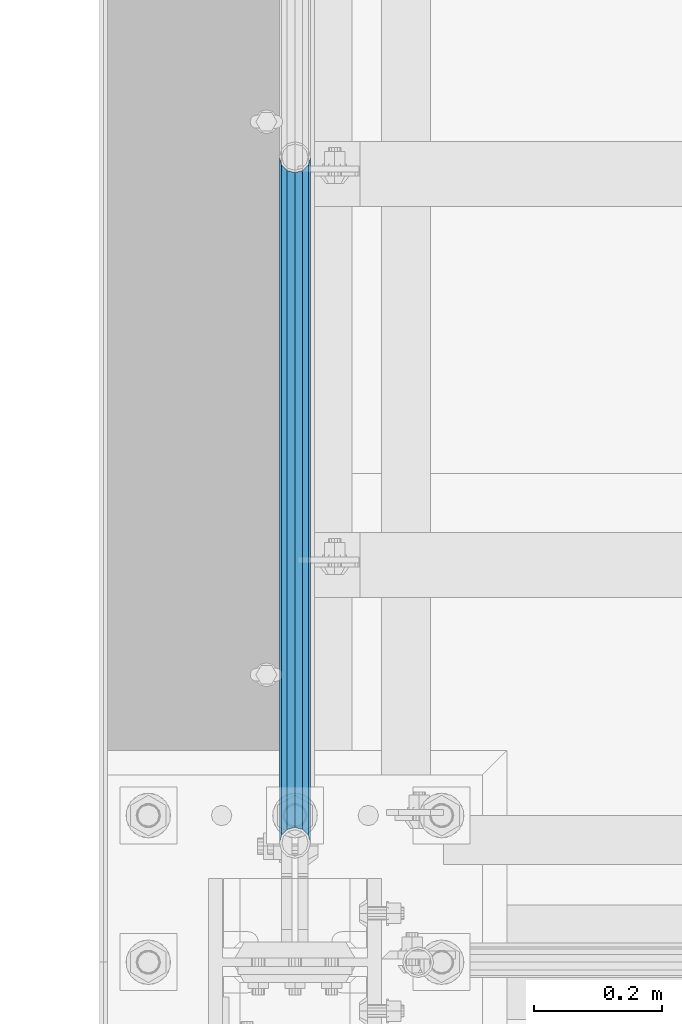
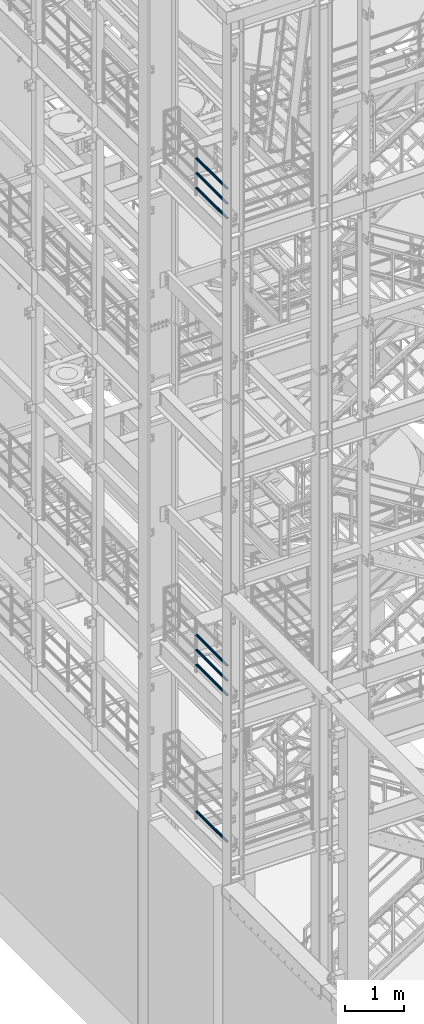
# One storey, part 933 of 1876: 7 beams, 3 elements without a shape of their own.
"""IFC2X3 building model written with IfcOpenShell, lengths in millimetres."""

import ifcopenshell
import ifcopenshell.guid

model = None  # the IFC model being written
_history = None  # IfcOwnerHistory: only IFC2X3 demands one
_inside = {}  # id of a spatial element -> (the spatial element, [elements in it])
_under = {}  # id of a project, library or spatial element -> (it, [spatial elements below it])
_declared = {}  # id of a project -> (the project, [libraries it declares])
_typed = {}  # id of a type object -> (the type object, [elements of that type])
_made_of = {}  # id of a material, layer set ... -> (it, [elements and type objects made of it])


def new_model(schema):
    """Start an empty IFC model of exactly this schema.

    Asked for "IFC4X3", IfcOpenShell would pick the latest addendum, in which some entities
    have other attributes; the version numbers below select the first issue.
    IFC2X3 requires an IfcOwnerHistory on every rooted entity: one is made here for all.
    """
    global model, _history
    if schema == "IFC4X3":
        model = ifcopenshell.file(schema_version=(4, 3, 0, 0))
    else:
        model = ifcopenshell.file(schema=schema)
    _inside.clear()
    _under.clear()
    _declared.clear()
    _typed.clear()
    _made_of.clear()
    _history = None
    if model.schema == "IFC2X3":
        org = make("IfcOrganization", Name="unknown")
        user = make(
            "IfcPersonAndOrganization",
            ThePerson=make("IfcPerson", FamilyName="unknown"),
            TheOrganization=org,
        )
        app = make(
            "IfcApplication",
            ApplicationDeveloper=org,
            Version="unknown",
            ApplicationFullName="unknown",
            ApplicationIdentifier="unknown",
        )
        _history = make(
            "IfcOwnerHistory",
            OwningUser=user,
            OwningApplication=app,
            ChangeAction="ADDED",
            CreationDate=0,
        )
    return model


def make(cls, **values):
    """One entity of the class cls with the attributes given. An attribute that is None is left unset."""
    return model.create_entity(
        cls, **{name: value for name, value in values.items() if value is not None}
    )


def rooted(cls, **values):
    """An entity with a GlobalId (a new one), such as an element, a storey or a relation."""
    return make(cls, GlobalId=ifcopenshell.guid.new(), OwnerHistory=_history, **values)


def si_unit(unit_type, name, prefix=None):
    """IfcSIUnit, for example si_unit("LENGTHUNIT", "METRE", prefix="MILLI")."""
    return make("IfcSIUnit", UnitType=unit_type, Prefix=prefix, Name=name)


def assignment(units):
    """IfcUnitAssignment: the units of a project."""
    return None if units is None else make("IfcUnitAssignment", Units=units)


def point(xyz):
    """IfcCartesianPoint."""
    return None if xyz is None else make("IfcCartesianPoint", Coordinates=xyz)


def direction(xyz):
    """IfcDirection."""
    return None if xyz is None else make("IfcDirection", DirectionRatios=xyz)


def frame(location, z_axis=None, x_axis=None):
    """IfcAxis2Placement3D, a coordinate frame: its origin and axes. An axis left out is left unset."""
    return make(
        "IfcAxis2Placement3D",
        Location=point(location),
        Axis=direction(z_axis),
        RefDirection=direction(x_axis),
    )


def origin_with_axes():
    """The frame at (0, 0, 0) with the z axis (0, 0, 1) and the x axis (1, 0, 0) written out."""
    return frame((0.0, 0.0, 0.0), z_axis=(0.0, 0.0, 1.0), x_axis=(1.0, 0.0, 0.0))


def place(relative_to, where):
    """IfcLocalPlacement: puts the frame where relative to a parent placement (None: the world)."""
    return make(
        "IfcLocalPlacement", PlacementRelTo=relative_to, RelativePlacement=where
    )


def context(
    kind, dimensions, precision=None, world=None, true_north=None, identifier=None
):
    """IfcGeometricRepresentationContext, for example the 3D "Model" context."""
    return make(
        "IfcGeometricRepresentationContext",
        ContextIdentifier=identifier,
        ContextType=kind,
        CoordinateSpaceDimension=dimensions,
        Precision=precision,
        WorldCoordinateSystem=world,
        TrueNorth=true_north,
    )


def subcontext(parent, identifier, kind, view, scale=None):
    """IfcGeometricRepresentationSubContext, for example "Body" below "Model"."""
    return make(
        "IfcGeometricRepresentationSubContext",
        ContextIdentifier=identifier,
        ContextType=kind,
        ParentContext=parent,
        TargetScale=scale,
        TargetView=view,
    )


def project(units=None, contexts=None):
    """IfcProject with its units and contexts."""
    return rooted(
        "IfcProject",
        Name="project",
        RepresentationContexts=contexts,
        UnitsInContext=assignment(units),
    )


def spatial(cls, under=None, at=None, **own):
    """A site, building, storey or space (cls), placed at a placement, below another one or the project."""
    s = rooted(cls, ObjectPlacement=at, **own)
    if under is not None:
        _under.setdefault(under.id(), (under, []))[1].append(s)
    return s


def faces_of(points, faces, orient=None, outer=None):
    """IfcFace entities. A face is a list of loops; a loop is a list of indices into points, from 0.

    orient and outer hold one flag for each loop. By default every Orientation is true, the
    first loop of a face is its IfcFaceOuterBound and the others are IfcFaceBound.
    """
    made = []
    for i, loops in enumerate(faces):
        bounds = []
        for j, loop in enumerate(loops):
            is_outer = j == 0 if outer is None else outer[i][j]
            bounds.append(
                make(
                    "IfcFaceOuterBound" if is_outer else "IfcFaceBound",
                    Bound=make("IfcPolyLoop", Polygon=[points[k] for k in loop]),
                    Orientation=True if orient is None else orient[i][j],
                )
            )
        made.append(make("IfcFace", Bounds=bounds))
    return made


def faceted_brep(points, faces, orient=None, outer=None, voids=None):
    """IfcFacetedBrep: a solid bounded by flat faces; with voids (closed shells), ...WithVoids."""
    shared = [point(p) for p in points]
    hull = make("IfcClosedShell", CfsFaces=faces_of(shared, faces, orient, outer))
    if voids is None:
        return make("IfcFacetedBrep", Outer=hull)
    return make(
        "IfcFacetedBrepWithVoids",
        Outer=hull,
        Voids=[
            make(cls, CfsFaces=faces_of(shared, fs, o, b)) for cls, fs, o, b in voids
        ],
    )


def shape(context_of_items, identifier, shape_type, items):
    """IfcShapeRepresentation: the items that make up one representation, for example the "Body"."""
    return make(
        "IfcShapeRepresentation",
        ContextOfItems=context_of_items,
        RepresentationIdentifier=identifier,
        RepresentationType=shape_type,
        Items=items,
    )


def material(Name=None, Category=None):
    """IfcMaterial."""
    return make("IfcMaterial", Name=Name, Category=Category)


def made_of(thing, what):
    """Note that an element or type object is made of a material, layer set ...; save() writes the relation."""
    if what is not None:
        _made_of.setdefault(what.id(), (what, []))[1].append(thing)
    return thing


def type_object(cls, material=None, **own):
    """A type object (cls), such as IfcWallType, which elements share."""
    return made_of(rooted(cls, **own), material)


def element(
    cls,
    number,
    at=None,
    inside=None,
    cuts=None,
    type_object=None,
    material=None,
    context=None,
    identifier="Body",
    shape_type=None,
    held_by="IfcProductDefinitionShape",
    body=None,
    shapes=None,
    **own,
):
    """One element of the class cls, such as IfcWall. Its Tag is "e" and its number.

    at: its placement. inside: the storey or other place that contains it. cuts: it is an
    opening in that element (IfcRelVoidsElement). A single representation is given by context,
    identifier, shape_type and body (its items); several are given by shapes. held_by: the class
    of the entity that holds the representations. save() writes the other relations.
    """
    e = rooted(cls, Tag="e%d" % number, ObjectPlacement=at, **own)
    if body is not None:
        shapes = [shape(context, identifier, shape_type, body)]
    if shapes is not None:
        e.Representation = make(held_by, Representations=shapes)
    if inside is not None:
        _inside.setdefault(inside.id(), (inside, []))[1].append(e)
    if cuts is not None:
        rooted(
            "IfcRelVoidsElement", RelatingBuildingElement=cuts, RelatedOpeningElement=e
        )
    if type_object is not None:
        _typed.setdefault(type_object.id(), (type_object, []))[1].append(e)
    return made_of(e, material)


def aggregate(whole, parts):
    """IfcRelAggregates: a whole, such as a stair, and the parts it consists of."""
    return rooted("IfcRelAggregates", RelatingObject=whole, RelatedObjects=parts)


def save(model, path):
    """Write the relations noted so far, then the file.

    IfcRelAggregates (storeys below a building ...), IfcRelContainedInSpatialStructure (elements
    in a storey), IfcRelDefinesByType, IfcRelAssociatesMaterial and IfcRelDeclares: one each for
    every whole, place, type object, material and project.
    """
    for whole, parts in _under.values():
        aggregate(whole, parts)
    for where, things in _inside.values():
        rooted(
            "IfcRelContainedInSpatialStructure",
            RelatedElements=things,
            RelatingStructure=where,
        )
    for kind, things in _typed.values():
        rooted("IfcRelDefinesByType", RelatedObjects=things, RelatingType=kind)
    for what, things in _made_of.values():
        rooted("IfcRelAssociatesMaterial", RelatedObjects=things, RelatingMaterial=what)
    for by, libraries in _declared.values():
        rooted("IfcRelDeclares", RelatingContext=by, RelatedDefinitions=libraries)
    model.write(path)


model = new_model("IFC2X3")

# Units and contexts
model_context = context("Model", 3, precision=1e-05, world=origin_with_axes())
body_context = subcontext(model_context, "Body", "Model", "MODEL_VIEW")
ifc_project = project(units=[si_unit("LENGTHUNIT", "METRE", prefix="MILLI"), si_unit("AREAUNIT", "SQUARE_METRE"), si_unit("VOLUMEUNIT", "CUBIC_METRE"), si_unit("MASSUNIT", "GRAM", prefix="KILO"), si_unit("TIMEUNIT", "SECOND"), si_unit("PLANEANGLEUNIT", "RADIAN"), si_unit("SOLIDANGLEUNIT", "STERADIAN"), si_unit("THERMODYNAMICTEMPERATUREUNIT", "DEGREE_CELSIUS"), si_unit("LUMINOUSINTENSITYUNIT", "LUMEN")], contexts=[model_context])

# Site, building, storey
site_placement = place(None, origin_with_axes())
site = spatial("IfcSite", under=ifc_project, at=site_placement, CompositionType="ELEMENT")
building_placement = place(site_placement, origin_with_axes())
building = spatial("IfcBuilding", under=site, at=building_placement, Name="Undefined", CompositionType="ELEMENT")
storey_placement = place(building_placement, origin_with_axes())
storey = spatial("IfcBuildingStorey", under=building, at=storey_placement, Name="Undefined", CompositionType="ELEMENT", Elevation=0.0)

# Assembly, beams
assembly_1_placement = place(storey_placement, origin_with_axes())
assembly_1 = element("IfcElementAssembly", 1, at=assembly_1_placement, inside=storey, Name="RAIL", AssemblyPlace="NOTDEFINED", PredefinedType="RIGID_FRAME")
ifc_material = material()
beam_type = type_object("IfcBeamType", Name="PIPE1-1/2SCH40", PredefinedType="NOTDEFINED")
beam_1_placement = place(assembly_1_placement, frame((2.63753463514149e-11, -5857.08124999999, 18145.125), z_axis=(0.0, 0.0, 1.0), x_axis=(0.0, -1.0, 0.0)))
beam_1 = element("IfcBeam", 2, at=beam_1_placement, type_object=beam_type, material=ifc_material, Name="RAIL", ObjectType="PIPE1-1/2SCH40", context=body_context, shape_type="Brep", body=[
    faceted_brep([(1047.96655700668, -12.0649999999996, 20.8971929933177), (1047.96655700668, -12.0649999999787, 15.8661214312015), (1047.47312856882, -10.2235000000001, 17.7076214311819), (1044.73375, 9.09494701772928e-13, 20.4470000000001), (1044.73375, 9.09494701772928e-13, 24.130000000001), (1047.47312856881, 10.2235000000001, 17.7076214311819), (1047.96655700668, 12.0650000000205, 15.8661214311578), (1047.96655700668, 12.0649999999996, 20.8971929933177), (1068.86375, 24.1300000000001, 0.0), (1056.79875, 20.8971929933186, 12.0649999999987), (1056.79875, 20.8971929933186, -12.0649999999987), (1053.60917843784, 17.7076214311801, 10.2235000000001), (1056.34855700666, 20.4470000000001, 0.0), (1053.60917843784, 17.7076214311801, -10.2235000000001), (1047.96655700668, 12.0650000000205, -15.8661214311578), (1047.96655700668, 12.0649999999996, -20.8971929933177), (1047.47312856881, 10.2235000000001, -17.7076214311819), (1044.73375, 0.0, -20.4470000000001), (1044.73375, 0.0, -24.130000000001), (1047.96655700668, -12.0649999999787, -15.8661214312015), (1047.96655700668, -12.0649999999996, -20.8971929933177), (1047.47312856882, -10.2235000000001, -17.7076214311819), (1068.86375, -24.1299999999792, 0.0), (1056.79875, -20.8971929933186, -12.0649999999987), (1056.79875, -20.8971929933186, 12.0649999999987), (1053.60917843788, -17.7076214311801, -10.2235000000001), (1056.3485570067, -20.4470000000001, 0.0), (1053.60917843788, -17.7076214311801, 10.2235000000001), (12.0650000000064, -20.8971929933177, -12.0649999999987), (20.8971929933249, -12.0650000000005, -20.8971929933177), (0.0, 24.1299999999992, 0.0), (12.0650000000064, 20.8971929933177, -12.0649999999987), (12.0650000000064, 20.8971929933177, 12.0649999999987), (20.8971929933249, 12.0650000000005, 20.8971929933177), (24.1300000000064, 0.0, 24.130000000001), (20.8971929933249, 12.0650000000005, -20.8971929933177), (24.1300000000063, 0.0, -24.130000000001), (24.1300000000063, 0.0, -20.4470000000001), (20.8971929933249, -12.0650000000005, -15.8661214311796), (21.3906214311868, -10.2235000000001, -17.7076214311819), (21.3906214311868, 10.2235000000001, -17.7076214311819), (20.8971929933249, 12.0650000000005, -15.8661214311796), (15.2545715621445, 17.7076214311801, -10.2235000000001), (12.5151929933249, 20.4470000000001, 0.0), (15.2545715621445, 17.7076214311801, 10.2235000000001), (20.8971929933249, 12.0650000000005, 15.8661214311796), (21.3906214311868, 10.2235000000001, 17.7076214311819), (24.1300000000064, 0.0, 20.4470000000001), (21.3906214311868, -10.2235000000001, 17.7076214311819), (20.8971929933249, -12.0650000000005, 15.8661214311796), (20.8971929933249, -12.0650000000005, 20.8971929933177), (12.0650000000064, -20.8971929933177, 12.0649999999987), (0.0, -24.1299999999992, 0.0), (15.2545715621445, -17.7076214311801, 10.2235000000001), (12.5151929933249, -20.4470000000001, 0.0), (15.2545715621445, -17.7076214311801, -10.2235000000001)], [[[0, 1, 2, 3, 4]], [[4, 3, 5, 6, 7]], [[8, 9, 10]], [[7, 6, 11, 12, 13, 14, 15, 10, 9]], [[16, 17, 18, 15, 14]], [[19, 20, 18, 17, 21]], [[22, 23, 24]], [[24, 23, 20, 19, 25, 26, 27, 1, 0]], [[28, 29, 20, 23]], [[30, 31, 32]], [[33, 34, 4, 7]], [[32, 33, 7, 9]], [[30, 32, 9, 8]], [[31, 30, 8, 10]], [[35, 31, 10, 15]], [[36, 35, 15, 18]], [[29, 36, 18, 20]], [[37, 36, 29, 38, 39]], [[40, 41, 35, 36, 37]], [[32, 31, 35, 41, 42, 43, 44, 45, 33]], [[33, 45, 46, 47, 34]], [[34, 47, 48, 49, 50]], [[34, 50, 0, 4]], [[50, 51, 24, 0]], [[51, 52, 22, 24]], [[52, 28, 23, 22]], [[51, 28, 52]], [[50, 49, 53, 54, 55, 38, 29, 28, 51]], [[55, 54, 26, 25]], [[21, 39, 38, 55, 25, 19]], [[37, 39, 21, 17]], [[40, 37, 17, 16]], [[42, 41, 40, 16, 14, 13]], [[43, 42, 13, 12]], [[44, 43, 12, 11]], [[5, 46, 45, 44, 11, 6]], [[47, 46, 5, 3]], [[48, 47, 3, 2]], [[53, 49, 48, 2, 1, 27]], [[54, 53, 27, 26]]]),
])
beam_2_placement = place(assembly_1_placement, frame((2.63753463514149e-11, -6925.94499999999, 18449.925), z_axis=(0.0, 0.0, -1.0), x_axis=(0.0, 1.0, 0.0)))
beam_2 = element("IfcBeam", 3, at=beam_2_placement, type_object=beam_type, material=ifc_material, Name="RAIL", ObjectType="PIPE1-1/2SCH40", context=body_context, shape_type="Brep", body=[
    faceted_brep([(0.0, 24.1299999999992, 0.0), (12.0650000000064, 20.8971929933177, -12.0649999999987), (12.0650000000064, 20.8971929933177, 12.0649999999987), (12.0650000000064, -20.8971929933177, 12.0649999999987), (12.0650000000064, -20.8971929933177, -12.0649999999987), (0.0, -24.1299999999992, 0.0), (20.8971929933249, -12.0650000000005, 20.8971929933177), (20.8971929933249, -12.0650000000005, 15.8661214311796), (15.2545715621445, -17.7076214311801, 10.2235000000001), (12.5151929933249, -20.4470000000001, 0.0), (15.2545715621445, -17.7076214311801, -10.2235000000001), (20.8971929933249, -12.0650000000005, -15.8661214311796), (20.8971929933249, -12.0650000000005, -20.8971929933177), (24.1300000000063, 0.0, -20.4470000000001), (24.1300000000063, 0.0, -24.130000000001), (21.3906214311868, -10.2235000000001, -17.7076214311819), (21.3906214311868, 10.2235000000001, -17.7076214311819), (20.8971929933249, 12.0650000000005, -15.8661214311796), (20.8971929933249, 12.0650000000005, -20.8971929933177), (15.2545715621445, 17.7076214311801, -10.2235000000001), (12.5151929933249, 20.4470000000001, 0.0), (15.2545715621445, 17.7076214311801, 10.2235000000001), (20.8971929933249, 12.0650000000005, 15.8661214311796), (20.8971929933249, 12.0650000000005, 20.8971929933177), (21.3906214311868, 10.2235000000001, 17.7076214311819), (24.1300000000064, 0.0, 20.4470000000001), (24.1300000000064, 0.0, 24.130000000001), (21.3906214311868, -10.2235000000001, 17.7076214311819), (1068.86375, 24.1300000000001, 0.0), (1056.79875, 20.8971929933186, -12.0649999999987), (1047.96655700668, 12.0649999999996, -20.8971929933177), (1068.86375, -24.1299999999792, 0.0), (1056.79875, -20.8971929933186, -12.0649999999987), (1056.79875, -20.8971929933186, 12.0649999999987), (1047.96655700668, -12.0649999999996, 20.8971929933177), (1047.96655700668, -12.0649999999996, -20.8971929933177), (1044.73375, 0.0, -24.130000000001), (1047.47312856881, 10.2235000000001, -17.7076214311819), (1044.73375, 0.0, -20.4470000000001), (1047.96655700668, 12.0650000000205, -15.8661214311578), (1047.96655700668, -12.0649999999787, -15.8661214312015), (1047.47312856882, -10.2235000000001, -17.7076214311819), (1053.60917843788, -17.7076214311801, -10.2235000000001), (1056.3485570067, -20.4470000000001, 0.0), (1053.60917843788, -17.7076214311801, 10.2235000000001), (1047.96655700668, -12.0649999999787, 15.8661214312015), (1047.47312856882, -10.2235000000001, 17.7076214311819), (1044.73375, 9.09494701772928e-13, 20.4470000000001), (1044.73375, 9.09494701772928e-13, 24.130000000001), (1047.96655700668, 12.0649999999996, 20.8971929933177), (1056.79875, 20.8971929933186, 12.0649999999987), (1047.96655700668, 12.0650000000205, 15.8661214311578), (1053.60917843784, 17.7076214311801, 10.2235000000001), (1056.34855700666, 20.4470000000001, 0.0), (1053.60917843784, 17.7076214311801, -10.2235000000001), (1047.47312856881, 10.2235000000001, 17.7076214311819)], [[[0, 1, 2]], [[3, 4, 5]], [[6, 7, 8, 9, 10, 11, 12, 4, 3]], [[13, 14, 12, 11, 15]], [[16, 17, 18, 14, 13]], [[2, 1, 18, 17, 19, 20, 21, 22, 23]], [[23, 22, 24, 25, 26]], [[26, 25, 27, 7, 6]], [[1, 0, 28, 29]], [[18, 1, 29, 30]], [[31, 32, 33]], [[6, 3, 33, 34]], [[3, 5, 31, 33]], [[5, 4, 32, 31]], [[4, 12, 35, 32]], [[12, 14, 36, 35]], [[14, 18, 30, 36]], [[37, 38, 36, 30, 39]], [[40, 35, 36, 38, 41]], [[33, 32, 35, 40, 42, 43, 44, 45, 34]], [[34, 45, 46, 47, 48]], [[26, 6, 34, 48]], [[2, 23, 49, 50]], [[23, 26, 48, 49]], [[0, 2, 50, 28]], [[28, 50, 29]], [[49, 51, 52, 53, 54, 39, 30, 29, 50]], [[48, 47, 55, 51, 49]], [[25, 24, 55, 47]], [[55, 24, 22, 21, 52, 51]], [[21, 20, 53, 52]], [[20, 19, 54, 53]], [[19, 17, 16, 37, 39, 54]], [[16, 13, 38, 37]], [[13, 15, 41, 38]], [[41, 15, 11, 10, 42, 40]], [[10, 9, 43, 42]], [[9, 8, 44, 43]], [[8, 7, 27, 46, 45, 44]], [[27, 25, 47, 46]]]),
])
beam_3_placement = place(assembly_1_placement, frame((2.63753463514149e-11, -6925.94499999999, 18754.725), z_axis=(0.0, 0.0, -1.0), x_axis=(0.0, 1.0, 0.0)))
beam_3 = element("IfcBeam", 4, at=beam_3_placement, type_object=beam_type, material=ifc_material, Name="RAIL", ObjectType="PIPE1-1/2SCH40", context=body_context, shape_type="Brep", body=[
    faceted_brep([(0.0, 24.1299999999992, 0.0), (12.0650000000064, 20.8971929933177, -12.0649999999987), (12.0650000000064, 20.8971929933177, 12.0649999999987), (12.0650000000064, -20.8971929933177, 12.0649999999987), (12.0650000000064, -20.8971929933177, -12.0649999999987), (0.0, -24.1299999999992, 0.0), (20.8971929933249, -12.0650000000005, 20.8971929933177), (20.8971929933249, -12.0650000000005, 15.8661214311796), (15.2545715621445, -17.7076214311801, 10.2235000000001), (12.5151929933249, -20.4470000000001, 0.0), (15.2545715621445, -17.7076214311801, -10.2235000000001), (20.8971929933249, -12.0650000000005, -15.8661214311796), (20.8971929933249, -12.0650000000005, -20.8971929933177), (24.1300000000063, 0.0, -20.4470000000001), (24.1300000000063, 0.0, -24.130000000001), (21.3906214311868, -10.2235000000001, -17.7076214311819), (21.3906214311868, 10.2235000000001, -17.7076214311819), (20.8971929933249, 12.0650000000005, -15.8661214311796), (20.8971929933249, 12.0650000000005, -20.8971929933177), (15.2545715621445, 17.7076214311801, -10.2235000000001), (12.5151929933249, 20.4470000000001, 0.0), (15.2545715621445, 17.7076214311801, 10.2235000000001), (20.8971929933249, 12.0650000000005, 15.8661214311796), (20.8971929933249, 12.0650000000005, 20.8971929933177), (21.3906214311868, 10.2235000000001, 17.7076214311819), (24.1300000000064, 0.0, 20.4470000000001), (24.1300000000064, 0.0, 24.130000000001), (21.3906214311868, -10.2235000000001, 17.7076214311819), (1068.86375, 24.1300000000001, 0.0), (1056.79875, 20.8971929933186, -12.0649999999987), (1047.96655700668, 12.0649999999996, -20.8971929933177), (1068.86375, -24.1299999999792, 0.0), (1056.79875, -20.8971929933186, -12.0649999999987), (1056.79875, -20.8971929933186, 12.0649999999987), (1047.96655700668, -12.0649999999996, 20.8971929933177), (1047.96655700668, -12.0649999999996, -20.8971929933177), (1044.73375, 0.0, -24.130000000001), (1047.47312856881, 10.2235000000001, -17.7076214311819), (1044.73375, 0.0, -20.4470000000001), (1047.96655700668, 12.0650000000205, -15.8661214311578), (1047.96655700668, -12.0649999999787, -15.8661214312015), (1047.47312856882, -10.2235000000001, -17.7076214311819), (1053.60917843788, -17.7076214311801, -10.2235000000001), (1056.3485570067, -20.4470000000001, 0.0), (1053.60917843788, -17.7076214311801, 10.2235000000001), (1047.96655700668, -12.0649999999787, 15.8661214312015), (1047.47312856882, -10.2235000000001, 17.7076214311819), (1044.73375, 9.09494701772928e-13, 20.4470000000001), (1044.73375, 9.09494701772928e-13, 24.130000000001), (1047.96655700668, 12.0649999999996, 20.8971929933177), (1056.79875, 20.8971929933186, 12.0649999999987), (1047.96655700668, 12.0650000000205, 15.8661214311578), (1053.60917843784, 17.7076214311801, 10.2235000000001), (1056.34855700666, 20.4470000000001, 0.0), (1053.60917843784, 17.7076214311801, -10.2235000000001), (1047.47312856881, 10.2235000000001, 17.7076214311819)], [[[0, 1, 2]], [[3, 4, 5]], [[6, 7, 8, 9, 10, 11, 12, 4, 3]], [[13, 14, 12, 11, 15]], [[16, 17, 18, 14, 13]], [[2, 1, 18, 17, 19, 20, 21, 22, 23]], [[23, 22, 24, 25, 26]], [[26, 25, 27, 7, 6]], [[1, 0, 28, 29]], [[18, 1, 29, 30]], [[31, 32, 33]], [[6, 3, 33, 34]], [[3, 5, 31, 33]], [[5, 4, 32, 31]], [[4, 12, 35, 32]], [[12, 14, 36, 35]], [[14, 18, 30, 36]], [[37, 38, 36, 30, 39]], [[40, 35, 36, 38, 41]], [[33, 32, 35, 40, 42, 43, 44, 45, 34]], [[34, 45, 46, 47, 48]], [[26, 6, 34, 48]], [[2, 23, 49, 50]], [[23, 26, 48, 49]], [[0, 2, 50, 28]], [[28, 50, 29]], [[49, 51, 52, 53, 54, 39, 30, 29, 50]], [[48, 47, 55, 51, 49]], [[25, 24, 55, 47]], [[55, 24, 22, 21, 52, 51]], [[21, 20, 53, 52]], [[20, 19, 54, 53]], [[19, 17, 16, 37, 39, 54]], [[16, 13, 38, 37]], [[13, 15, 41, 38]], [[41, 15, 11, 10, 42, 40]], [[10, 9, 43, 42]], [[9, 8, 44, 43]], [[8, 7, 27, 46, 45, 44]], [[27, 25, 47, 46]]]),
])
aggregate(assembly_1, [beam_1, beam_2, beam_3])

assembly_2_placement = place(storey_placement, origin_with_axes())
assembly_2 = element("IfcElementAssembly", 5, at=assembly_2_placement, inside=storey, Name="RAIL", AssemblyPlace="NOTDEFINED", PredefinedType="RIGID_FRAME")
beam_4_placement = place(assembly_2_placement, frame((2.63753463514149e-11, -5857.08124999999, 8315.325), z_axis=(0.0, 0.0, 1.0), x_axis=(0.0, -1.0, 0.0)))
beam_4 = element("IfcBeam", 6, at=beam_4_placement, type_object=beam_type, material=ifc_material, Name="RAIL", ObjectType="PIPE1-1/2SCH40", context=body_context, shape_type="Brep", body=[
    faceted_brep([(1047.96655700668, -12.0649999999996, 20.8971929933177), (1047.96655700668, -12.0649999999787, 15.8661214312015), (1047.47312856882, -10.2235000000001, 17.7076214311819), (1044.73375, 9.09494701772928e-13, 20.4470000000001), (1044.73375, 9.09494701772928e-13, 24.130000000001), (1047.47312856881, 10.2235000000001, 17.7076214311819), (1047.96655700668, 12.0650000000205, 15.8661214311578), (1047.96655700668, 12.0649999999996, 20.8971929933177), (1068.86375, 24.1300000000001, 0.0), (1056.79875, 20.8971929933186, 12.0649999999987), (1056.79875, 20.8971929933186, -12.0649999999987), (1053.60917843784, 17.7076214311801, 10.2235000000001), (1056.34855700666, 20.4470000000001, 0.0), (1053.60917843784, 17.7076214311801, -10.2235000000001), (1047.96655700668, 12.0650000000205, -15.8661214311578), (1047.96655700668, 12.0649999999996, -20.8971929933177), (1047.47312856881, 10.2235000000001, -17.7076214311819), (1044.73375, 0.0, -20.4470000000001), (1044.73375, 0.0, -24.130000000001), (1047.96655700668, -12.0649999999787, -15.8661214312015), (1047.96655700668, -12.0649999999996, -20.8971929933177), (1047.47312856882, -10.2235000000001, -17.7076214311819), (1068.86375, -24.1299999999792, 0.0), (1056.79875, -20.8971929933186, -12.0649999999987), (1056.79875, -20.8971929933186, 12.0649999999987), (1053.60917843788, -17.7076214311801, -10.2235000000001), (1056.3485570067, -20.4470000000001, 0.0), (1053.60917843788, -17.7076214311801, 10.2235000000001), (12.0650000000064, -20.8971929933177, -12.0649999999987), (20.8971929933249, -12.0650000000005, -20.8971929933177), (0.0, 24.1299999999992, 0.0), (12.0650000000064, 20.8971929933177, -12.0649999999987), (12.0650000000064, 20.8971929933177, 12.0649999999987), (20.8971929933249, 12.0650000000005, 20.8971929933177), (24.1300000000064, 0.0, 24.130000000001), (20.8971929933249, 12.0650000000005, -20.8971929933177), (24.1300000000063, 0.0, -24.130000000001), (24.1300000000063, 0.0, -20.4470000000001), (20.8971929933249, -12.0650000000005, -15.8661214311796), (21.3906214311868, -10.2235000000001, -17.7076214311819), (21.3906214311868, 10.2235000000001, -17.7076214311819), (20.8971929933249, 12.0650000000005, -15.8661214311796), (15.2545715621445, 17.7076214311801, -10.2235000000001), (12.5151929933249, 20.4470000000001, 0.0), (15.2545715621445, 17.7076214311801, 10.2235000000001), (20.8971929933249, 12.0650000000005, 15.8661214311796), (21.3906214311868, 10.2235000000001, 17.7076214311819), (24.1300000000064, 0.0, 20.4470000000001), (21.3906214311868, -10.2235000000001, 17.7076214311819), (20.8971929933249, -12.0650000000005, 15.8661214311796), (20.8971929933249, -12.0650000000005, 20.8971929933177), (12.0650000000064, -20.8971929933177, 12.0649999999987), (0.0, -24.1299999999992, 0.0), (15.2545715621445, -17.7076214311801, 10.2235000000001), (12.5151929933249, -20.4470000000001, 0.0), (15.2545715621445, -17.7076214311801, -10.2235000000001)], [[[0, 1, 2, 3, 4]], [[4, 3, 5, 6, 7]], [[8, 9, 10]], [[7, 6, 11, 12, 13, 14, 15, 10, 9]], [[16, 17, 18, 15, 14]], [[19, 20, 18, 17, 21]], [[22, 23, 24]], [[24, 23, 20, 19, 25, 26, 27, 1, 0]], [[28, 29, 20, 23]], [[30, 31, 32]], [[33, 34, 4, 7]], [[32, 33, 7, 9]], [[30, 32, 9, 8]], [[31, 30, 8, 10]], [[35, 31, 10, 15]], [[36, 35, 15, 18]], [[29, 36, 18, 20]], [[37, 36, 29, 38, 39]], [[40, 41, 35, 36, 37]], [[32, 31, 35, 41, 42, 43, 44, 45, 33]], [[33, 45, 46, 47, 34]], [[34, 47, 48, 49, 50]], [[34, 50, 0, 4]], [[50, 51, 24, 0]], [[51, 52, 22, 24]], [[52, 28, 23, 22]], [[51, 28, 52]], [[50, 49, 53, 54, 55, 38, 29, 28, 51]], [[55, 54, 26, 25]], [[21, 39, 38, 55, 25, 19]], [[37, 39, 21, 17]], [[40, 37, 17, 16]], [[42, 41, 40, 16, 14, 13]], [[43, 42, 13, 12]], [[44, 43, 12, 11]], [[5, 46, 45, 44, 11, 6]], [[47, 46, 5, 3]], [[48, 47, 3, 2]], [[53, 49, 48, 2, 1, 27]], [[54, 53, 27, 26]]]),
])
beam_5_placement = place(assembly_2_placement, frame((2.63753463514149e-11, -6925.94499999999, 8620.125), z_axis=(0.0, 0.0, -1.0), x_axis=(0.0, 1.0, 0.0)))
beam_5 = element("IfcBeam", 7, at=beam_5_placement, type_object=beam_type, material=ifc_material, Name="RAIL", ObjectType="PIPE1-1/2SCH40", context=body_context, shape_type="Brep", body=[
    faceted_brep([(0.0, 24.1299999999992, 0.0), (12.0650000000064, 20.8971929933177, -12.0649999999987), (12.0650000000064, 20.8971929933177, 12.0649999999987), (12.0650000000064, -20.8971929933177, 12.0649999999987), (12.0650000000064, -20.8971929933177, -12.0649999999987), (0.0, -24.1299999999992, 0.0), (20.8971929933249, -12.0650000000005, 20.8971929933177), (20.8971929933249, -12.0650000000005, 15.8661214311796), (15.2545715621445, -17.7076214311801, 10.2235000000001), (12.5151929933249, -20.4470000000001, 0.0), (15.2545715621445, -17.7076214311801, -10.2235000000001), (20.8971929933249, -12.0650000000005, -15.8661214311796), (20.8971929933249, -12.0650000000005, -20.8971929933177), (24.1300000000063, 0.0, -20.4470000000001), (24.1300000000063, 0.0, -24.130000000001), (21.3906214311868, -10.2235000000001, -17.7076214311819), (21.3906214311868, 10.2235000000001, -17.7076214311819), (20.8971929933249, 12.0650000000005, -15.8661214311796), (20.8971929933249, 12.0650000000005, -20.8971929933177), (15.2545715621445, 17.7076214311801, -10.2235000000001), (12.5151929933249, 20.4470000000001, 0.0), (15.2545715621445, 17.7076214311801, 10.2235000000001), (20.8971929933249, 12.0650000000005, 15.8661214311796), (20.8971929933249, 12.0650000000005, 20.8971929933177), (21.3906214311868, 10.2235000000001, 17.7076214311819), (24.1300000000064, 0.0, 20.4470000000001), (24.1300000000064, 0.0, 24.130000000001), (21.3906214311868, -10.2235000000001, 17.7076214311819), (1068.86375, 24.1300000000001, 0.0), (1056.79875, 20.8971929933186, -12.0649999999987), (1047.96655700668, 12.0649999999996, -20.8971929933177), (1068.86375, -24.1299999999792, 0.0), (1056.79875, -20.8971929933186, -12.0649999999987), (1056.79875, -20.8971929933186, 12.0649999999987), (1047.96655700668, -12.0649999999996, 20.8971929933177), (1047.96655700668, -12.0649999999996, -20.8971929933177), (1044.73375, 0.0, -24.130000000001), (1047.47312856881, 10.2235000000001, -17.7076214311819), (1044.73375, 0.0, -20.4470000000001), (1047.96655700668, 12.0650000000205, -15.8661214311578), (1047.96655700668, -12.0649999999787, -15.8661214312015), (1047.47312856882, -10.2235000000001, -17.7076214311819), (1053.60917843788, -17.7076214311801, -10.2235000000001), (1056.3485570067, -20.4470000000001, 0.0), (1053.60917843788, -17.7076214311801, 10.2235000000001), (1047.96655700668, -12.0649999999787, 15.8661214312015), (1047.47312856882, -10.2235000000001, 17.7076214311819), (1044.73375, 9.09494701772928e-13, 20.4470000000001), (1044.73375, 9.09494701772928e-13, 24.130000000001), (1047.96655700668, 12.0649999999996, 20.8971929933177), (1056.79875, 20.8971929933186, 12.0649999999987), (1047.96655700668, 12.0650000000205, 15.8661214311578), (1053.60917843784, 17.7076214311801, 10.2235000000001), (1056.34855700666, 20.4470000000001, 0.0), (1053.60917843784, 17.7076214311801, -10.2235000000001), (1047.47312856881, 10.2235000000001, 17.7076214311819)], [[[0, 1, 2]], [[3, 4, 5]], [[6, 7, 8, 9, 10, 11, 12, 4, 3]], [[13, 14, 12, 11, 15]], [[16, 17, 18, 14, 13]], [[2, 1, 18, 17, 19, 20, 21, 22, 23]], [[23, 22, 24, 25, 26]], [[26, 25, 27, 7, 6]], [[1, 0, 28, 29]], [[18, 1, 29, 30]], [[31, 32, 33]], [[6, 3, 33, 34]], [[3, 5, 31, 33]], [[5, 4, 32, 31]], [[4, 12, 35, 32]], [[12, 14, 36, 35]], [[14, 18, 30, 36]], [[37, 38, 36, 30, 39]], [[40, 35, 36, 38, 41]], [[33, 32, 35, 40, 42, 43, 44, 45, 34]], [[34, 45, 46, 47, 48]], [[26, 6, 34, 48]], [[2, 23, 49, 50]], [[23, 26, 48, 49]], [[0, 2, 50, 28]], [[28, 50, 29]], [[49, 51, 52, 53, 54, 39, 30, 29, 50]], [[48, 47, 55, 51, 49]], [[25, 24, 55, 47]], [[55, 24, 22, 21, 52, 51]], [[21, 20, 53, 52]], [[20, 19, 54, 53]], [[19, 17, 16, 37, 39, 54]], [[16, 13, 38, 37]], [[13, 15, 41, 38]], [[41, 15, 11, 10, 42, 40]], [[10, 9, 43, 42]], [[9, 8, 44, 43]], [[8, 7, 27, 46, 45, 44]], [[27, 25, 47, 46]]]),
])
beam_6_placement = place(assembly_2_placement, frame((2.63753463514149e-11, -6925.94499999999, 8924.925), z_axis=(0.0, 0.0, -1.0), x_axis=(0.0, 1.0, 0.0)))
beam_6 = element("IfcBeam", 8, at=beam_6_placement, type_object=beam_type, material=ifc_material, Name="RAIL", ObjectType="PIPE1-1/2SCH40", context=body_context, shape_type="Brep", body=[
    faceted_brep([(0.0, 24.1299999999992, 0.0), (12.0650000000064, 20.8971929933177, -12.0649999999987), (12.0650000000064, 20.8971929933177, 12.0649999999987), (12.0650000000064, -20.8971929933177, 12.0649999999987), (12.0650000000064, -20.8971929933177, -12.0649999999987), (0.0, -24.1299999999992, 0.0), (20.8971929933249, -12.0650000000005, 20.8971929933177), (20.8971929933249, -12.0650000000005, 15.8661214311796), (15.2545715621445, -17.7076214311801, 10.2235000000001), (12.5151929933249, -20.4470000000001, 0.0), (15.2545715621445, -17.7076214311801, -10.2235000000001), (20.8971929933249, -12.0650000000005, -15.8661214311796), (20.8971929933249, -12.0650000000005, -20.8971929933177), (24.1300000000063, 0.0, -20.4470000000001), (24.1300000000063, 0.0, -24.130000000001), (21.3906214311868, -10.2235000000001, -17.7076214311819), (21.3906214311868, 10.2235000000001, -17.7076214311819), (20.8971929933249, 12.0650000000005, -15.8661214311796), (20.8971929933249, 12.0650000000005, -20.8971929933177), (15.2545715621445, 17.7076214311801, -10.2235000000001), (12.5151929933249, 20.4470000000001, 0.0), (15.2545715621445, 17.7076214311801, 10.2235000000001), (20.8971929933249, 12.0650000000005, 15.8661214311796), (20.8971929933249, 12.0650000000005, 20.8971929933177), (21.3906214311868, 10.2235000000001, 17.7076214311819), (24.1300000000064, 0.0, 20.4470000000001), (24.1300000000064, 0.0, 24.130000000001), (21.3906214311868, -10.2235000000001, 17.7076214311819), (1068.86375, 24.1300000000001, 0.0), (1056.79875, 20.8971929933186, -12.0649999999987), (1047.96655700668, 12.0649999999996, -20.8971929933177), (1068.86375, -24.1299999999792, 0.0), (1056.79875, -20.8971929933186, -12.0649999999987), (1056.79875, -20.8971929933186, 12.0649999999987), (1047.96655700668, -12.0649999999996, 20.8971929933177), (1047.96655700668, -12.0649999999996, -20.8971929933177), (1044.73375, 0.0, -24.130000000001), (1047.47312856881, 10.2235000000001, -17.7076214311819), (1044.73375, 0.0, -20.4470000000001), (1047.96655700668, 12.0650000000205, -15.8661214311578), (1047.96655700668, -12.0649999999787, -15.8661214312015), (1047.47312856882, -10.2235000000001, -17.7076214311819), (1053.60917843788, -17.7076214311801, -10.2235000000001), (1056.3485570067, -20.4470000000001, 0.0), (1053.60917843788, -17.7076214311801, 10.2235000000001), (1047.96655700668, -12.0649999999787, 15.8661214312015), (1047.47312856882, -10.2235000000001, 17.7076214311819), (1044.73375, 9.09494701772928e-13, 20.4470000000001), (1044.73375, 9.09494701772928e-13, 24.130000000001), (1047.96655700668, 12.0649999999996, 20.8971929933177), (1056.79875, 20.8971929933186, 12.0649999999987), (1047.96655700668, 12.0650000000205, 15.8661214311578), (1053.60917843784, 17.7076214311801, 10.2235000000001), (1056.34855700666, 20.4470000000001, 0.0), (1053.60917843784, 17.7076214311801, -10.2235000000001), (1047.47312856881, 10.2235000000001, 17.7076214311819)], [[[0, 1, 2]], [[3, 4, 5]], [[6, 7, 8, 9, 10, 11, 12, 4, 3]], [[13, 14, 12, 11, 15]], [[16, 17, 18, 14, 13]], [[2, 1, 18, 17, 19, 20, 21, 22, 23]], [[23, 22, 24, 25, 26]], [[26, 25, 27, 7, 6]], [[1, 0, 28, 29]], [[18, 1, 29, 30]], [[31, 32, 33]], [[6, 3, 33, 34]], [[3, 5, 31, 33]], [[5, 4, 32, 31]], [[4, 12, 35, 32]], [[12, 14, 36, 35]], [[14, 18, 30, 36]], [[37, 38, 36, 30, 39]], [[40, 35, 36, 38, 41]], [[33, 32, 35, 40, 42, 43, 44, 45, 34]], [[34, 45, 46, 47, 48]], [[26, 6, 34, 48]], [[2, 23, 49, 50]], [[23, 26, 48, 49]], [[0, 2, 50, 28]], [[28, 50, 29]], [[49, 51, 52, 53, 54, 39, 30, 29, 50]], [[48, 47, 55, 51, 49]], [[25, 24, 55, 47]], [[55, 24, 22, 21, 52, 51]], [[21, 20, 53, 52]], [[20, 19, 54, 53]], [[19, 17, 16, 37, 39, 54]], [[16, 13, 38, 37]], [[13, 15, 41, 38]], [[41, 15, 11, 10, 42, 40]], [[10, 9, 43, 42]], [[9, 8, 44, 43]], [[8, 7, 27, 46, 45, 44]], [[27, 25, 47, 46]]]),
])
aggregate(assembly_2, [beam_4, beam_5, beam_6])

# Assembly, beam
assembly_3_placement = place(storey_placement, origin_with_axes())
assembly_3 = element("IfcElementAssembly", 9, at=assembly_3_placement, inside=storey, Name="RAIL", AssemblyPlace="NOTDEFINED", PredefinedType="RIGID_FRAME")
beam_7_placement = place(assembly_3_placement, frame((2.81943357549608e-11, -5857.08124999999, 5292.72500110474), z_axis=(0.0, 0.0, 1.0), x_axis=(0.0, -1.0, 0.0)))
beam_7 = element("IfcBeam", 10, at=beam_7_placement, type_object=beam_type, material=ifc_material, Name="RAIL", ObjectType="PIPE1-1/2SCH40", context=body_context, shape_type="Brep", body=[
    faceted_brep([(1047.96655700668, -12.0649999999996, 20.8971929933177), (1047.96655700668, -12.0649999999787, 15.8661214312015), (1047.47312856882, -10.2235000000001, 17.7076214311819), (1044.73375, 9.09494701772928e-13, 20.4470000000001), (1044.73375, 9.09494701772928e-13, 24.130000000001), (1047.47312856881, 10.2235000000001, 17.7076214311819), (1047.96655700668, 12.0650000000205, 15.8661214311578), (1047.96655700668, 12.0649999999996, 20.8971929933177), (1068.86375, 24.1300000000001, 0.0), (1056.79875, 20.8971929933186, 12.0649999999987), (1056.79875, 20.8971929933186, -12.0649999999987), (1053.60917843784, 17.7076214311801, 10.2235000000001), (1056.34855700666, 20.4470000000001, 0.0), (1053.60917843784, 17.7076214311801, -10.2235000000001), (1047.96655700668, 12.0650000000205, -15.8661214311578), (1047.96655700668, 12.0649999999996, -20.8971929933177), (1047.47312856881, 10.2235000000001, -17.7076214311819), (1044.73375, 0.0, -20.4470000000001), (1044.73375, 0.0, -24.130000000001), (1047.96655700668, -12.0649999999787, -15.8661214312015), (1047.96655700668, -12.0649999999996, -20.8971929933177), (1047.47312856882, -10.2235000000001, -17.7076214311819), (1068.86375, -24.1299999999792, 0.0), (1056.79875, -20.8971929933186, -12.0649999999987), (1056.79875, -20.8971929933186, 12.0649999999987), (1053.60917843788, -17.7076214311801, -10.2235000000001), (1056.3485570067, -20.4470000000001, 0.0), (1053.60917843788, -17.7076214311801, 10.2235000000001), (12.0650000000064, -20.8971929933177, -12.0649999999987), (20.8971929933249, -12.0650000000005, -20.8971929933177), (0.0, 24.1299999999992, 0.0), (12.0650000000064, 20.8971929933177, -12.0649999999987), (12.0650000000064, 20.8971929933177, 12.0649999999987), (20.8971929933249, 12.0650000000005, 20.8971929933177), (24.1300000000064, 0.0, 24.130000000001), (20.8971929933249, 12.0650000000005, -20.8971929933177), (24.1300000000063, 0.0, -24.130000000001), (24.1300000000063, 0.0, -20.4470000000001), (20.8971929933249, -12.0650000000005, -15.8661214311796), (21.3906214311868, -10.2235000000001, -17.7076214311819), (21.3906214311868, 10.2235000000001, -17.7076214311819), (20.8971929933249, 12.0650000000005, -15.8661214311796), (15.2545715621445, 17.7076214311801, -10.2235000000001), (12.5151929933249, 20.4470000000001, 0.0), (15.2545715621445, 17.7076214311801, 10.2235000000001), (20.8971929933249, 12.0650000000005, 15.8661214311796), (21.3906214311868, 10.2235000000001, 17.7076214311819), (24.1300000000064, 0.0, 20.4470000000001), (21.3906214311868, -10.2235000000001, 17.7076214311819), (20.8971929933249, -12.0650000000005, 15.8661214311796), (20.8971929933249, -12.0650000000005, 20.8971929933177), (12.0650000000064, -20.8971929933177, 12.0649999999987), (0.0, -24.1299999999992, 0.0), (15.2545715621445, -17.7076214311801, 10.2235000000001), (12.5151929933249, -20.4470000000001, 0.0), (15.2545715621445, -17.7076214311801, -10.2235000000001)], [[[0, 1, 2, 3, 4]], [[4, 3, 5, 6, 7]], [[8, 9, 10]], [[7, 6, 11, 12, 13, 14, 15, 10, 9]], [[16, 17, 18, 15, 14]], [[19, 20, 18, 17, 21]], [[22, 23, 24]], [[24, 23, 20, 19, 25, 26, 27, 1, 0]], [[28, 29, 20, 23]], [[30, 31, 32]], [[33, 34, 4, 7]], [[32, 33, 7, 9]], [[30, 32, 9, 8]], [[31, 30, 8, 10]], [[35, 31, 10, 15]], [[36, 35, 15, 18]], [[29, 36, 18, 20]], [[37, 36, 29, 38, 39]], [[40, 41, 35, 36, 37]], [[32, 31, 35, 41, 42, 43, 44, 45, 33]], [[33, 45, 46, 47, 34]], [[34, 47, 48, 49, 50]], [[34, 50, 0, 4]], [[50, 51, 24, 0]], [[51, 52, 22, 24]], [[52, 28, 23, 22]], [[51, 28, 52]], [[50, 49, 53, 54, 55, 38, 29, 28, 51]], [[55, 54, 26, 25]], [[21, 39, 38, 55, 25, 19]], [[37, 39, 21, 17]], [[40, 37, 17, 16]], [[42, 41, 40, 16, 14, 13]], [[43, 42, 13, 12]], [[44, 43, 12, 11]], [[5, 46, 45, 44, 11, 6]], [[47, 46, 5, 3]], [[48, 47, 3, 2]], [[53, 49, 48, 2, 1, 27]], [[54, 53, 27, 26]]]),
])
aggregate(assembly_3, [beam_7])

save(model, "model.ifc")
